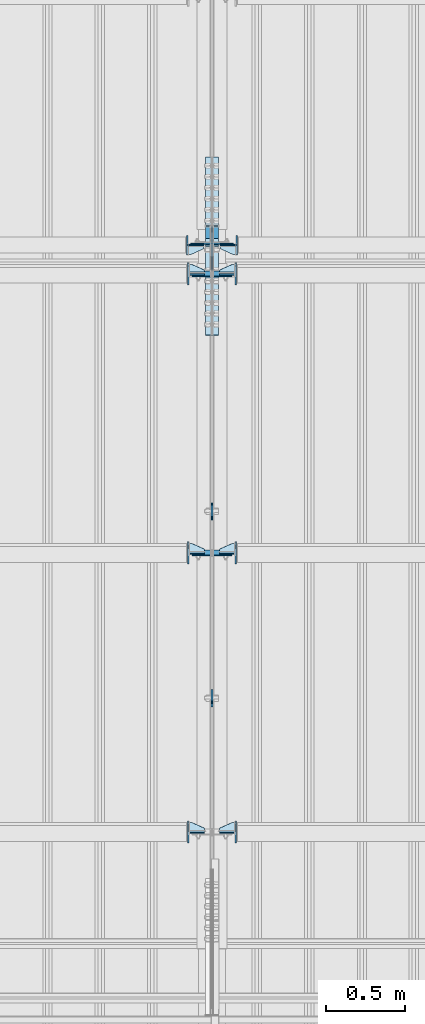
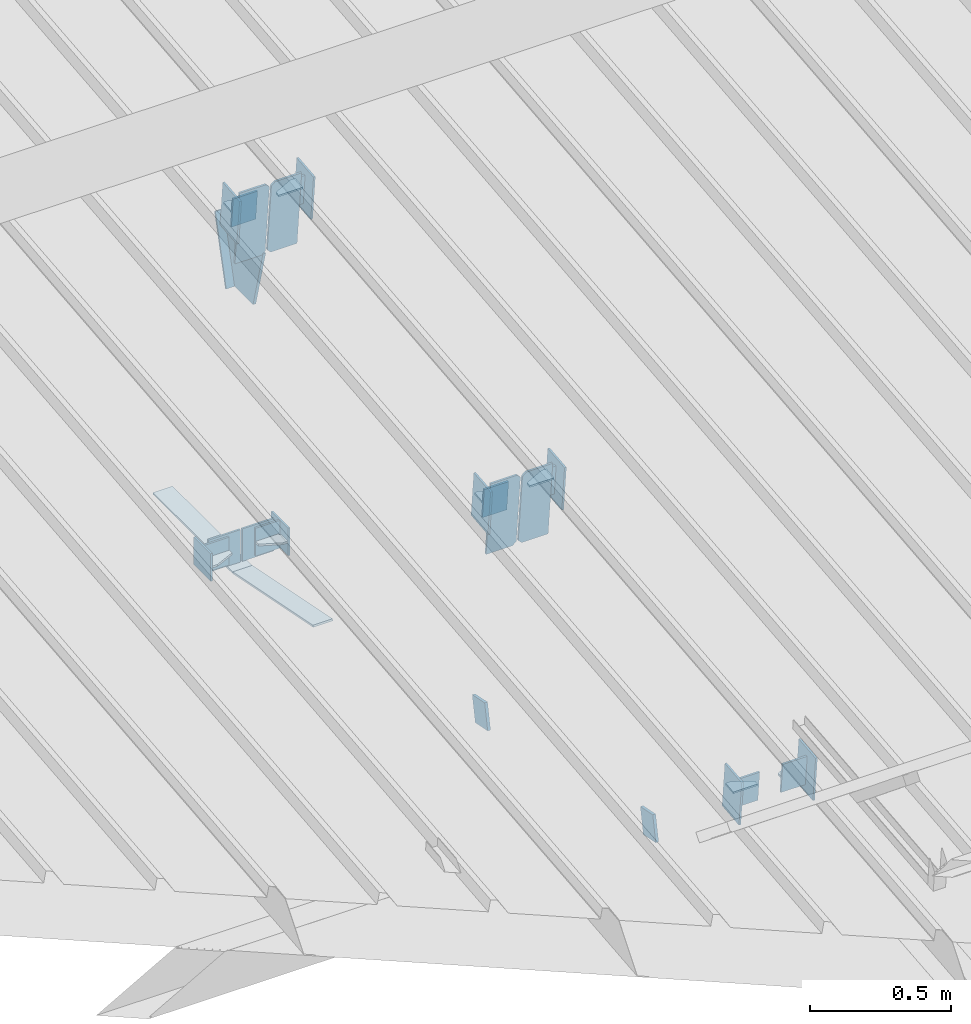
# One storey, part 126 of 709: 36 plates, 12 elements without a shape of their own.
"""IFC4 building model written with IfcOpenShell, lengths in millimetres."""

from ifc_helpers import new_model, si_unit, direction, frame, origin_with_axes, place, context, subcontext, project, spatial, line, indexed_curve, outline, extrude, material, element, aggregate, save


model = new_model("IFC4")

# Units and contexts
model_context = context("Model", 3, precision=0.2, world=origin_with_axes(), true_north=direction((0.0, 1.0)))
body_context = subcontext(model_context, "Body", "Model", "MODEL_VIEW")
ifc_project = project(units=[si_unit("LENGTHUNIT", "METRE", prefix="MILLI"), si_unit("AREAUNIT", "SQUARE_METRE"), si_unit("VOLUMEUNIT", "CUBIC_METRE"), si_unit("MASSUNIT", "GRAM", prefix="KILO"), si_unit("TIMEUNIT", "SECOND"), si_unit("PLANEANGLEUNIT", "RADIAN"), si_unit("SOLIDANGLEUNIT", "STERADIAN"), si_unit("THERMODYNAMICTEMPERATUREUNIT", "DEGREE_CELSIUS"), si_unit("LUMINOUSINTENSITYUNIT", "LUMEN")], contexts=[model_context])

# Site, building, storey
site_placement = place(None, origin_with_axes())
site = spatial("IfcSite", under=ifc_project, at=site_placement, CompositionType="ELEMENT")
building_placement = place(site_placement, origin_with_axes())
building = spatial("IfcBuilding", under=site, at=building_placement, Name="Undefined", CompositionType="ELEMENT")
storey_placement = place(building_placement, origin_with_axes())
storey = spatial("IfcBuildingStorey", under=building, at=storey_placement, Name="Undefined", CompositionType="ELEMENT", Elevation=0.0)

# Assembly, plates
assembly_1_placement = place(storey_placement, frame((28000.0, 346.0, 7089.70002), z_axis=(1.0, 0.0, 0.0), x_axis=(0.0, 0.9950371902, 0.099503719)))
assembly_1 = element("IfcElementAssembly", 1, at=assembly_1_placement, inside=storey)
ifc_material = material(Name="C355-6", Category="STEEL")
plate_1_placement = place(assembly_1_placement, frame((5169.0059, 163.0, -127.0), z_axis=(1.0, 0.0, 0.0), x_axis=(0.0, 0.0, 1.0)))
plate_1 = element("IfcPlate", 2, at=plate_1_placement, material=ifc_material, ObjectType="585", context=body_context, shape_type="SolidModel", body=[
    extrude(outline(indexed_curve([(0.0, 0.0), (108.0, 0.0), (123.0, 15.0), (123.0, 311.0), (108.0, 326.0), (0.0, 326.0)], segments=[line(1, 2, 3, 4, 5, 6, 1)])), frame((0.0, 0.0, 4.0), z_axis=(0.0, 0.0, 1.0), x_axis=(1.0, 0.0, 0.0)), (0.0, 0.0, -1.0), 8.0),
])
plate_2_placement = place(assembly_1_placement, frame((5169.0059, 163.0, 127.0), z_axis=(-1.0, 0.0, 0.0), x_axis=(0.0, 0.0, -1.0)))
plate_2 = element("IfcPlate", 3, at=plate_2_placement, material=ifc_material, ObjectType="585", context=body_context, shape_type="SolidModel", body=[
    extrude(outline(indexed_curve([(0.0, 0.0), (108.0, 0.0), (123.0, 15.0), (123.0, 311.0), (108.0, 326.0), (0.0, 326.0)], segments=[line(1, 2, 3, 4, 5, 6, 1)])), frame((0.0, 0.0, 4.0), z_axis=(0.0, 0.0, 1.0), x_axis=(1.0, 0.0, 0.0)), (0.0, 0.0, -1.0), 8.0),
])
plate_3_placement = place(assembly_1_placement, frame((3383.44474, 163.0, 127.0), z_axis=(-1.0, 0.0, 0.0), x_axis=(0.0, 0.0, -1.0)))
plate_3 = element("IfcPlate", 4, at=plate_3_placement, material=ifc_material, ObjectType="585", context=body_context, shape_type="SolidModel", body=[
    extrude(outline(indexed_curve([(0.0, 0.0), (108.0, 0.0), (123.0, 15.0), (123.0, 311.0), (108.0, 326.0), (0.0, 326.0)], segments=[line(1, 2, 3, 4, 5, 6, 1)])), frame((0.0, 0.0, 4.0), z_axis=(0.0, 0.0, 1.0), x_axis=(1.0, 0.0, 0.0)), (0.0, 0.0, -1.0), 8.0),
])
plate_4_placement = place(assembly_1_placement, frame((3383.44474, 163.0, -127.0), z_axis=(1.0, 0.0, 0.0), x_axis=(0.0, 0.0, 1.0)))
plate_4 = element("IfcPlate", 5, at=plate_4_placement, material=ifc_material, ObjectType="585", context=body_context, shape_type="SolidModel", body=[
    extrude(outline(indexed_curve([(0.0, 0.0), (108.0, 0.0), (123.0, 15.0), (123.0, 311.0), (108.0, 326.0), (0.0, 326.0)], segments=[line(1, 2, 3, 4, 5, 6, 1)])), frame((0.0, 0.0, 4.0), z_axis=(0.0, 0.0, 1.0), x_axis=(1.0, 0.0, 0.0)), (0.0, 0.0, -1.0), 8.0),
])
plate_5_placement = place(assembly_1_placement, frame((5220.02987, -437.93487, 0.0), z_axis=(0.0, 0.0, -1.0), x_axis=(-0.1614213634, 0.9868855777, 0.0)))
plate_5 = element("IfcPlate", 6, at=plate_5_placement, material=ifc_material, ObjectType="442", context=body_context, shape_type="SolidModel", body=[
    extrude(outline(indexed_curve([(0.0, 0.0), (270.19115, 0.0), (225.20717, 275.01958), (-33.64648, 125.57036)], segments=[line(1, 2, 3, 4, 1)])), frame((0.0, 0.0, 6.0), z_axis=(0.0, 0.0, 1.0), x_axis=(1.0, 0.0, 0.0)), (0.0, 0.0, -1.0), 12.0),
])
plate_6_placement = place(assembly_1_placement, frame((5458.83099, -172.70172, -40.0), z_axis=(-0.9353786626, 0.3536477874, 0.0), x_axis=(-0.3536477874, -0.9353786626, 0.0)))
plate_6 = element("IfcPlate", 7, at=plate_6_placement, material=ifc_material, ObjectType="443", context=body_context, shape_type="SolidModel", body=[
    extrude(outline(indexed_curve([(0.0, 0.0), (298.89845, 0.0), (298.89845, 80.0), (0.0, 80.0)], segments=[line(1, 2, 3, 4, 1)])), frame((0.0, 0.0, 4.0), z_axis=(0.0, 0.0, 1.0), x_axis=(1.0, 0.0, 0.0)), (0.0, 0.0, -1.0), 8.0),
])
aggregate(assembly_1, [plate_1, plate_2, plate_3, plate_4, plate_5, plate_6])

assembly_2_placement = place(storey_placement, frame((28000.0, 5668.61344, 5980.00002), z_axis=(1.0, 0.0, 0.0), x_axis=(0.0, 1.0, 0.0)))
assembly_2 = element("IfcElementAssembly", 8, at=assembly_2_placement, inside=storey)
plate_7_placement = place(assembly_2_placement, frame((-569.03779, 109.72834, -40.0), z_axis=(-0.1961161349, -0.9805806757, 0.0), x_axis=(0.9805806757, -0.1961161349, 0.0)))
plate_7 = element("IfcPlate", 9, at=plate_7_placement, material=ifc_material, ObjectType="447", context=body_context, shape_type="SolidModel", body=[
    extrude(outline(indexed_curve([(0.0, 0.0), (579.50696, 0.0), (579.50696, 80.0), (0.0, 80.0)], segments=[line(1, 2, 3, 4, 1)])), frame((0.0, 0.0, 4.0), z_axis=(0.0, 0.0, 1.0), x_axis=(1.0, 0.0, 0.0)), (0.0, 0.0, -1.0), 8.0),
])
plate_8_placement = place(assembly_2_placement, frame((564.38656, -4.0, -40.0), z_axis=(0.0, 1.0, 0.0), x_axis=(-1.0, 0.0, 0.0)))
plate_8 = element("IfcPlate", 10, at=plate_8_placement, material=ifc_material, ObjectType="446", context=body_context, shape_type="SolidModel", body=[
    extrude(outline(indexed_curve([(0.0, 0.0), (564.38656, 0.0), (564.38656, 80.0), (0.0, 80.0)], segments=[line(1, 2, 3, 4, 1)])), frame((0.0, 0.0, 4.0), z_axis=(0.0, 0.0, 1.0), x_axis=(1.0, 0.0, 0.0)), (0.0, 0.0, -1.0), 8.0),
])
plate_9_placement = place(assembly_2_placement, frame((12.38656, 164.3, -134.0), z_axis=(1.0, 0.0, 0.0), x_axis=(0.0, 0.0, 1.0)))
plate_9 = element("IfcPlate", 11, at=plate_9_placement, material=ifc_material, ObjectType="558", context=body_context, shape_type="SolidModel", body=[
    extrude(outline(indexed_curve([(0.0, 0.0), (130.0, 0.0), (130.0, 140.0), (0.0, 140.0)], segments=[line(1, 2, 3, 4, 1)])), frame((0.0, 0.0, 4.0), z_axis=(0.0, 0.0, 1.0), x_axis=(1.0, 0.0, 0.0)), (0.0, 0.0, -1.0), 8.0),
])
plate_10_placement = place(assembly_2_placement, frame((12.38656, 164.3, 134.0), z_axis=(-1.0, 0.0, 0.0), x_axis=(0.0, 0.0, -1.0)))
plate_10 = element("IfcPlate", 12, at=plate_10_placement, material=ifc_material, ObjectType="558", context=body_context, shape_type="SolidModel", body=[
    extrude(outline(indexed_curve([(0.0, 0.0), (130.0, 0.0), (130.0, 140.0), (0.0, 140.0)], segments=[line(1, 2, 3, 4, 1)])), frame((0.0, 0.0, 4.0), z_axis=(0.0, 0.0, 1.0), x_axis=(1.0, 0.0, 0.0)), (0.0, 0.0, -1.0), 8.0),
])
aggregate(assembly_2, [plate_7, plate_8, plate_9, plate_10])

# Assembly, plate
assembly_3_placement = place(storey_placement, frame((28000.0, 2754.64076, 6685.17103), z_axis=(-1.0, 0.0, 0.0), x_axis=(0.0, 0.9805806757, -0.1961161349)))
assembly_3 = element("IfcElementAssembly", 13, at=assembly_3_placement, inside=storey)
plate_11_placement = place(assembly_3_placement, origin_with_axes())
plate_11 = element("IfcPlate", 14, at=plate_11_placement, material=ifc_material, ObjectType="491", context=body_context, shape_type="SolidModel", body=[
    extrude(outline(indexed_curve([(0.0, 0.0), (90.0, 0.0), (90.0, 110.0), (0.0, 110.0)], segments=[line(1, 2, 3, 4, 1)])), frame((0.0, 0.0, 6.0), z_axis=(0.0, 0.0, 1.0), x_axis=(1.0, 0.0, 0.0)), (0.0, 0.0, -1.0), 12.0),
])
aggregate(assembly_3, [plate_11])

assembly_4_placement = place(storey_placement, frame((28000.0, 3944.17031, 6447.26512), z_axis=(-1.0, 0.0, 0.0), x_axis=(0.0, 0.9805806757, -0.1961161349)))
assembly_4 = element("IfcElementAssembly", 15, at=assembly_4_placement, inside=storey)
plate_12_placement = place(assembly_4_placement, origin_with_axes())
plate_12 = element("IfcPlate", 16, at=plate_12_placement, material=ifc_material, ObjectType="491", context=body_context, shape_type="SolidModel", body=[
    extrude(outline(indexed_curve([(0.0, 0.0), (90.0, 0.0), (90.0, 110.0), (0.0, 110.0)], segments=[line(1, 2, 3, 4, 1)])), frame((0.0, 0.0, 6.0), z_axis=(0.0, 0.0, 1.0), x_axis=(1.0, 0.0, 0.0)), (0.0, 0.0, -1.0), 12.0),
])
aggregate(assembly_4, [plate_12])

# Assembly, plates
assembly_5_placement = place(storey_placement, frame((22000.0, 5673.0, 6074.30002), z_axis=(0.0, -1.0, 0.0), x_axis=(1.0, 0.0, 0.0)))
assembly_5 = element("IfcElementAssembly", 17, at=assembly_5_placement, inside=storey)
plate_13_placement = place(assembly_5_placement, frame((5842.0, 60.0, -60.0), z_axis=(1.0, 0.0, 0.0), x_axis=(0.0, 0.0, 1.0)))
plate_13 = element("IfcPlate", 18, at=plate_13_placement, material=ifc_material, ObjectType="559", context=body_context, shape_type="SolidModel", body=[
    extrude(outline(indexed_curve([(0.0, 0.0), (120.0, 0.0), (120.0, 120.0), (0.0, 120.0)], segments=[line(1, 2, 3, 4, 1)])), frame((0.0, 0.0, 4.0), z_axis=(0.0, 0.0, 1.0), x_axis=(1.0, 0.0, 0.0)), (0.0, 0.0, -1.0), 8.0),
])
plate_14_placement = place(assembly_5_placement, frame((5946.0, 0.0, 60.0), z_axis=(0.0, 1.0, 0.0), x_axis=(0.0, 0.0, -1.0)))
plate_14 = element("IfcPlate", 19, at=plate_14_placement, material=ifc_material, ObjectType="561", context=body_context, shape_type="SolidModel", body=[
    extrude(outline(indexed_curve([(0.0, 80.0), (36.0, 0.0), (56.0, 0.0), (56.0, 90.0), (46.0, 100.0), (0.0, 100.0)], segments=[line(1, 2, 3, 4, 5, 6, 1)])), frame((0.0, 0.0, 4.0), z_axis=(0.0, 0.0, 1.0), x_axis=(1.0, 0.0, 0.0)), (0.0, 0.0, -1.0), 8.0),
])
plate_15_placement = place(assembly_5_placement, frame((5946.0, 60.0, 0.0), z_axis=(0.0, 0.0, -1.0), x_axis=(0.0, -1.0, 0.0)))
plate_15 = element("IfcPlate", 20, at=plate_15_placement, material=ifc_material, ObjectType="560", context=body_context, shape_type="SolidModel", body=[
    extrude(outline(indexed_curve([(0.0, 0.0), (120.0, 0.0), (120.0, 100.0), (0.0, 100.0)], segments=[line(1, 2, 3, 4, 1)])), frame((0.0, 0.0, 4.0), z_axis=(0.0, 0.0, 1.0), x_axis=(1.0, 0.0, 0.0)), (0.0, 0.0, -1.0), 8.0),
])
aggregate(assembly_5, [plate_13, plate_14, plate_15])

assembly_6_placement = place(storey_placement, frame((28000.0, 5673.0, 6074.30002), z_axis=(0.0, -1.0, 0.0), x_axis=(1.0, 0.0, 0.0)))
assembly_6 = element("IfcElementAssembly", 21, at=assembly_6_placement, inside=storey)
plate_16_placement = place(assembly_6_placement, frame((54.0, -60.0, 0.0), z_axis=(0.0, 0.0, -1.0), x_axis=(0.0, 1.0, 0.0)))
plate_16 = element("IfcPlate", 22, at=plate_16_placement, material=ifc_material, ObjectType="560", context=body_context, shape_type="SolidModel", body=[
    extrude(outline(indexed_curve([(0.0, 0.0), (120.0, 0.0), (120.0, 100.0), (0.0, 100.0)], segments=[line(1, 2, 3, 4, 1)])), frame((0.0, 0.0, 4.0), z_axis=(0.0, 0.0, 1.0), x_axis=(1.0, 0.0, 0.0)), (0.0, 0.0, -1.0), 8.0),
])
plate_17_placement = place(assembly_6_placement, frame((158.0, -60.0, -60.0), z_axis=(-1.0, 0.0, 0.0), x_axis=(0.0, 0.0, 1.0)))
plate_17 = element("IfcPlate", 23, at=plate_17_placement, material=ifc_material, ObjectType="559", context=body_context, shape_type="SolidModel", body=[
    extrude(outline(indexed_curve([(0.0, 0.0), (120.0, 0.0), (120.0, 120.0), (0.0, 120.0)], segments=[line(1, 2, 3, 4, 1)])), frame((0.0, 0.0, 4.0), z_axis=(0.0, 0.0, 1.0), x_axis=(1.0, 0.0, 0.0)), (0.0, 0.0, -1.0), 8.0),
])
plate_18_placement = place(assembly_6_placement, frame((54.0, 0.0, 60.0), z_axis=(0.0, -1.0, 0.0), x_axis=(0.0, 0.0, -1.0)))
plate_18 = element("IfcPlate", 24, at=plate_18_placement, material=ifc_material, ObjectType="561", context=body_context, shape_type="SolidModel", body=[
    extrude(outline(indexed_curve([(0.0, 80.0), (36.0, 0.0), (56.0, 0.0), (56.0, 90.0), (46.0, 100.0), (0.0, 100.0)], segments=[line(1, 2, 3, 4, 5, 6, 1)])), frame((0.0, 0.0, 4.0), z_axis=(0.0, 0.0, 1.0), x_axis=(1.0, 0.0, 0.0)), (0.0, 0.0, -1.0), 8.0),
])
aggregate(assembly_6, [plate_16, plate_17, plate_18])

assembly_7_placement = place(storey_placement, frame((22000.0, 1936.65012, 7322.12913), z_axis=(0.0, 0.9950371902, 0.099503719), x_axis=(1.0, 0.0, 0.0)))
assembly_7 = element("IfcElementAssembly", 25, at=assembly_7_placement, inside=storey)
plate_19_placement = place(assembly_7_placement, frame((5953.0, 0.0, 60.0), z_axis=(0.0, -1.0, 0.0), x_axis=(-1.0, 0.0, 0.0)))
plate_19 = element("IfcPlate", 26, at=plate_19_placement, material=ifc_material, ObjectType="588", context=body_context, shape_type="SolidModel", body=[
    extrude(outline(indexed_curve([(0.0, 36.0), (80.0, 0.0), (100.0, 0.0), (100.0, 56.0), (0.0, 56.0)], segments=[line(1, 2, 3, 4, 5, 1)])), frame((0.0, 0.0, 4.0), z_axis=(0.0, 0.0, 1.0), x_axis=(1.0, 0.0, 0.0)), (0.0, 0.0, -1.0), 8.0),
])
plate_20_placement = place(assembly_7_placement, frame((5953.0, 65.0, 0.0), z_axis=(0.0, 0.0, 1.0), x_axis=(-1.0, 0.0, 0.0)))
plate_20 = element("IfcPlate", 27, at=plate_20_placement, material=ifc_material, ObjectType="587", context=body_context, shape_type="SolidModel", body=[
    extrude(outline(indexed_curve([(0.0, 0.0), (100.0, 0.0), (100.0, 130.0), (0.0, 130.0)], segments=[line(1, 2, 3, 4, 1)])), frame((0.0, 0.0, 4.0), z_axis=(0.0, 0.0, 1.0), x_axis=(1.0, 0.0, 0.0)), (0.0, 0.0, -1.0), 8.0),
])
plate_21_placement = place(assembly_7_placement, frame((5849.0, -98.0, 60.0), z_axis=(1.0, 0.0, 0.0), x_axis=(0.0, 0.0, -1.0)))
plate_21 = element("IfcPlate", 28, at=plate_21_placement, material=ifc_material, ObjectType="586", context=body_context, shape_type="SolidModel", body=[
    extrude(outline(indexed_curve([(0.0, 0.0), (120.0, 0.0), (120.0, 196.0), (0.0, 196.0)], segments=[line(1, 2, 3, 4, 1)])), frame((0.0, 0.0, 4.0), z_axis=(0.0, 0.0, 1.0), x_axis=(1.0, 0.0, 0.0)), (0.0, 0.0, -1.0), 8.0),
])
aggregate(assembly_7, [plate_19, plate_20, plate_21])

assembly_8_placement = place(storey_placement, frame((22000.0, 3713.34988, 7499.7991), z_axis=(0.0, 0.9950371902, 0.099503719), x_axis=(1.0, 0.0, 0.0)))
assembly_8 = element("IfcElementAssembly", 29, at=assembly_8_placement, inside=storey)
plate_22_placement = place(assembly_8_placement, frame((5953.0, 0.0, 60.0), z_axis=(0.0, -1.0, 0.0), x_axis=(-1.0, 0.0, 0.0)))
plate_22 = element("IfcPlate", 30, at=plate_22_placement, material=ifc_material, ObjectType="588", context=body_context, shape_type="SolidModel", body=[
    extrude(outline(indexed_curve([(0.0, 36.0), (80.0, 0.0), (100.0, 0.0), (100.0, 56.0), (0.0, 56.0)], segments=[line(1, 2, 3, 4, 5, 1)])), frame((0.0, 0.0, 4.0), z_axis=(0.0, 0.0, 1.0), x_axis=(1.0, 0.0, 0.0)), (0.0, 0.0, -1.0), 8.0),
])
plate_23_placement = place(assembly_8_placement, frame((5953.0, 65.0, 0.0), z_axis=(0.0, 0.0, 1.0), x_axis=(-1.0, 0.0, 0.0)))
plate_23 = element("IfcPlate", 31, at=plate_23_placement, material=ifc_material, ObjectType="587", context=body_context, shape_type="SolidModel", body=[
    extrude(outline(indexed_curve([(0.0, 0.0), (100.0, 0.0), (100.0, 130.0), (0.0, 130.0)], segments=[line(1, 2, 3, 4, 1)])), frame((0.0, 0.0, 4.0), z_axis=(0.0, 0.0, 1.0), x_axis=(1.0, 0.0, 0.0)), (0.0, 0.0, -1.0), 8.0),
])
plate_24_placement = place(assembly_8_placement, frame((5849.0, -98.0, 60.0), z_axis=(1.0, 0.0, 0.0), x_axis=(0.0, 0.0, -1.0)))
plate_24 = element("IfcPlate", 32, at=plate_24_placement, material=ifc_material, ObjectType="586", context=body_context, shape_type="SolidModel", body=[
    extrude(outline(indexed_curve([(0.0, 0.0), (120.0, 0.0), (120.0, 196.0), (0.0, 196.0)], segments=[line(1, 2, 3, 4, 1)])), frame((0.0, 0.0, 4.0), z_axis=(0.0, 0.0, 1.0), x_axis=(1.0, 0.0, 0.0)), (0.0, 0.0, -1.0), 8.0),
])
aggregate(assembly_8, [plate_22, plate_23, plate_24])

assembly_9_placement = place(storey_placement, frame((22000.0, 5490.04963, 7677.46908), z_axis=(0.0, 0.9950371902, 0.099503719), x_axis=(1.0, 0.0, 0.0)))
assembly_9 = element("IfcElementAssembly", 33, at=assembly_9_placement, inside=storey)
plate_25_placement = place(assembly_9_placement, frame((5953.0, 0.0, 60.0), z_axis=(0.0, -1.0, 0.0), x_axis=(-1.0, 0.0, 0.0)))
plate_25 = element("IfcPlate", 34, at=plate_25_placement, material=ifc_material, ObjectType="588", context=body_context, shape_type="SolidModel", body=[
    extrude(outline(indexed_curve([(0.0, 36.0), (80.0, 0.0), (100.0, 0.0), (100.0, 56.0), (0.0, 56.0)], segments=[line(1, 2, 3, 4, 5, 1)])), frame((0.0, 0.0, 4.0), z_axis=(0.0, 0.0, 1.0), x_axis=(1.0, 0.0, 0.0)), (0.0, 0.0, -1.0), 8.0),
])
plate_26_placement = place(assembly_9_placement, frame((5849.0, -98.0, 60.0), z_axis=(1.0, 0.0, 0.0), x_axis=(0.0, 0.0, -1.0)))
plate_26 = element("IfcPlate", 35, at=plate_26_placement, material=ifc_material, ObjectType="586", context=body_context, shape_type="SolidModel", body=[
    extrude(outline(indexed_curve([(0.0, 0.0), (120.0, 0.0), (120.0, 196.0), (0.0, 196.0)], segments=[line(1, 2, 3, 4, 1)])), frame((0.0, 0.0, 4.0), z_axis=(0.0, 0.0, 1.0), x_axis=(1.0, 0.0, 0.0)), (0.0, 0.0, -1.0), 8.0),
])
plate_27_placement = place(assembly_9_placement, frame((5953.0, 65.0, 0.0), z_axis=(0.0, 0.0, 1.0), x_axis=(-1.0, 0.0, 0.0)))
plate_27 = element("IfcPlate", 36, at=plate_27_placement, material=ifc_material, ObjectType="587", context=body_context, shape_type="SolidModel", body=[
    extrude(outline(indexed_curve([(0.0, 0.0), (100.0, 0.0), (100.0, 130.0), (0.0, 130.0)], segments=[line(1, 2, 3, 4, 1)])), frame((0.0, 0.0, 4.0), z_axis=(0.0, 0.0, 1.0), x_axis=(1.0, 0.0, 0.0)), (0.0, 0.0, -1.0), 8.0),
])
aggregate(assembly_9, [plate_25, plate_26, plate_27])

assembly_10_placement = place(storey_placement, frame((28000.0, 1936.65012, 7322.12913), z_axis=(0.0, 0.9950371902, 0.099503719), x_axis=(1.0, 0.0, 0.0)))
assembly_10 = element("IfcElementAssembly", 37, at=assembly_10_placement, inside=storey)
plate_28_placement = place(assembly_10_placement, frame((151.0, -98.0, -60.0), z_axis=(-1.0, 0.0, 0.0), x_axis=(0.0, 0.0, 1.0)))
plate_28 = element("IfcPlate", 38, at=plate_28_placement, material=ifc_material, ObjectType="586", context=body_context, shape_type="SolidModel", body=[
    extrude(outline(indexed_curve([(0.0, 0.0), (120.0, 0.0), (120.0, 196.0), (0.0, 196.0)], segments=[line(1, 2, 3, 4, 1)])), frame((0.0, 0.0, 4.0), z_axis=(0.0, 0.0, 1.0), x_axis=(1.0, 0.0, 0.0)), (0.0, 0.0, -1.0), 8.0),
])
plate_29_placement = place(assembly_10_placement, frame((47.0, -65.0, 0.0), z_axis=(0.0, 0.0, 1.0), x_axis=(1.0, 0.0, 0.0)))
plate_29 = element("IfcPlate", 39, at=plate_29_placement, material=ifc_material, ObjectType="587", context=body_context, shape_type="SolidModel", body=[
    extrude(outline(indexed_curve([(0.0, 0.0), (100.0, 0.0), (100.0, 130.0), (0.0, 130.0)], segments=[line(1, 2, 3, 4, 1)])), frame((0.0, 0.0, 4.0), z_axis=(0.0, 0.0, 1.0), x_axis=(1.0, 0.0, 0.0)), (0.0, 0.0, -1.0), 8.0),
])
plate_30_placement = place(assembly_10_placement, frame((47.0, 0.0, 60.0), z_axis=(0.0, 1.0, 0.0), x_axis=(1.0, 0.0, 0.0)))
plate_30 = element("IfcPlate", 40, at=plate_30_placement, material=ifc_material, ObjectType="588", context=body_context, shape_type="SolidModel", body=[
    extrude(outline(indexed_curve([(0.0, 36.0), (80.0, 0.0), (100.0, 0.0), (100.0, 56.0), (0.0, 56.0)], segments=[line(1, 2, 3, 4, 5, 1)])), frame((0.0, 0.0, 4.0), z_axis=(0.0, 0.0, 1.0), x_axis=(1.0, 0.0, 0.0)), (0.0, 0.0, -1.0), 8.0),
])
aggregate(assembly_10, [plate_28, plate_29, plate_30])

assembly_11_placement = place(storey_placement, frame((28000.0, 3713.34988, 7499.7991), z_axis=(0.0, 0.9950371902, 0.099503719), x_axis=(1.0, 0.0, 0.0)))
assembly_11 = element("IfcElementAssembly", 41, at=assembly_11_placement, inside=storey)
plate_31_placement = place(assembly_11_placement, frame((47.0, 0.0, 60.0), z_axis=(0.0, 1.0, 0.0), x_axis=(1.0, 0.0, 0.0)))
plate_31 = element("IfcPlate", 42, at=plate_31_placement, material=ifc_material, ObjectType="588", context=body_context, shape_type="SolidModel", body=[
    extrude(outline(indexed_curve([(0.0, 36.0), (80.0, 0.0), (100.0, 0.0), (100.0, 56.0), (0.0, 56.0)], segments=[line(1, 2, 3, 4, 5, 1)])), frame((0.0, 0.0, 4.0), z_axis=(0.0, 0.0, 1.0), x_axis=(1.0, 0.0, 0.0)), (0.0, 0.0, -1.0), 8.0),
])
plate_32_placement = place(assembly_11_placement, frame((151.0, -98.0, -60.0), z_axis=(-1.0, 0.0, 0.0), x_axis=(0.0, 0.0, 1.0)))
plate_32 = element("IfcPlate", 43, at=plate_32_placement, material=ifc_material, ObjectType="586", context=body_context, shape_type="SolidModel", body=[
    extrude(outline(indexed_curve([(0.0, 0.0), (120.0, 0.0), (120.0, 196.0), (0.0, 196.0)], segments=[line(1, 2, 3, 4, 1)])), frame((0.0, 0.0, 4.0), z_axis=(0.0, 0.0, 1.0), x_axis=(1.0, 0.0, 0.0)), (0.0, 0.0, -1.0), 8.0),
])
plate_33_placement = place(assembly_11_placement, frame((47.0, -65.0, 0.0), z_axis=(0.0, 0.0, 1.0), x_axis=(1.0, 0.0, 0.0)))
plate_33 = element("IfcPlate", 44, at=plate_33_placement, material=ifc_material, ObjectType="587", context=body_context, shape_type="SolidModel", body=[
    extrude(outline(indexed_curve([(0.0, 0.0), (100.0, 0.0), (100.0, 130.0), (0.0, 130.0)], segments=[line(1, 2, 3, 4, 1)])), frame((0.0, 0.0, 4.0), z_axis=(0.0, 0.0, 1.0), x_axis=(1.0, 0.0, 0.0)), (0.0, 0.0, -1.0), 8.0),
])
aggregate(assembly_11, [plate_31, plate_32, plate_33])

assembly_12_placement = place(storey_placement, frame((28000.0, 5490.04963, 7677.46908), z_axis=(0.0, 0.9950371902, 0.099503719), x_axis=(1.0, 0.0, 0.0)))
assembly_12 = element("IfcElementAssembly", 45, at=assembly_12_placement, inside=storey)
plate_34_placement = place(assembly_12_placement, frame((47.0, 0.0, 60.0), z_axis=(0.0, 1.0, 0.0), x_axis=(1.0, 0.0, 0.0)))
plate_34 = element("IfcPlate", 46, at=plate_34_placement, material=ifc_material, ObjectType="588", context=body_context, shape_type="SolidModel", body=[
    extrude(outline(indexed_curve([(0.0, 36.0), (80.0, 0.0), (100.0, 0.0), (100.0, 56.0), (0.0, 56.0)], segments=[line(1, 2, 3, 4, 5, 1)])), frame((0.0, 0.0, 4.0), z_axis=(0.0, 0.0, 1.0), x_axis=(1.0, 0.0, 0.0)), (0.0, 0.0, -1.0), 8.0),
])
plate_35_placement = place(assembly_12_placement, frame((47.0, -65.0, 0.0), z_axis=(0.0, 0.0, 1.0), x_axis=(1.0, 0.0, 0.0)))
plate_35 = element("IfcPlate", 47, at=plate_35_placement, material=ifc_material, ObjectType="587", context=body_context, shape_type="SolidModel", body=[
    extrude(outline(indexed_curve([(0.0, 0.0), (100.0, 0.0), (100.0, 130.0), (0.0, 130.0)], segments=[line(1, 2, 3, 4, 1)])), frame((0.0, 0.0, 4.0), z_axis=(0.0, 0.0, 1.0), x_axis=(1.0, 0.0, 0.0)), (0.0, 0.0, -1.0), 8.0),
])
plate_36_placement = place(assembly_12_placement, frame((151.0, -98.0, -60.0), z_axis=(-1.0, 0.0, 0.0), x_axis=(0.0, 0.0, 1.0)))
plate_36 = element("IfcPlate", 48, at=plate_36_placement, material=ifc_material, ObjectType="586", context=body_context, shape_type="SolidModel", body=[
    extrude(outline(indexed_curve([(0.0, 0.0), (120.0, 0.0), (120.0, 196.0), (0.0, 196.0)], segments=[line(1, 2, 3, 4, 1)])), frame((0.0, 0.0, 4.0), z_axis=(0.0, 0.0, 1.0), x_axis=(1.0, 0.0, 0.0)), (0.0, 0.0, -1.0), 8.0),
])
aggregate(assembly_12, [plate_34, plate_35, plate_36])

save(model, "model.ifc")
